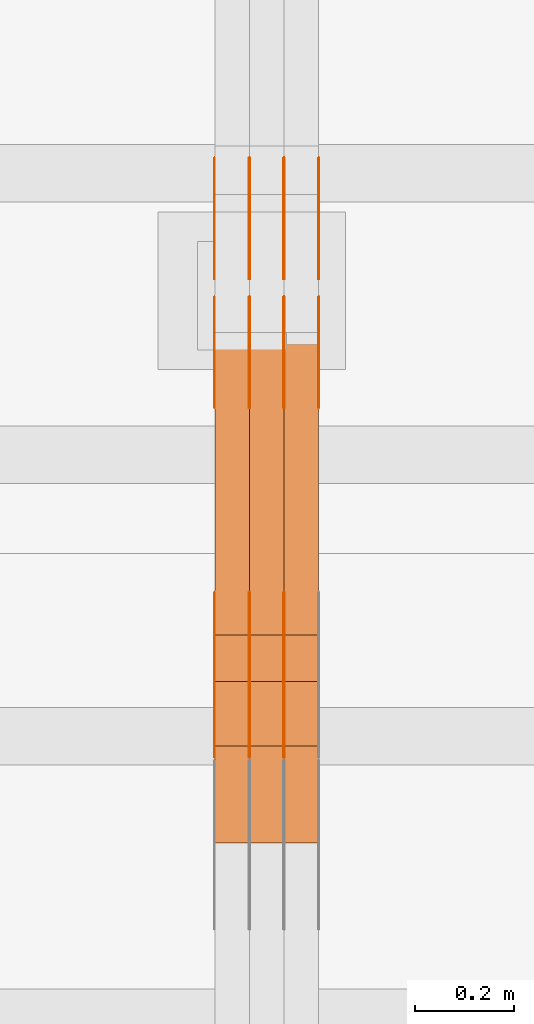
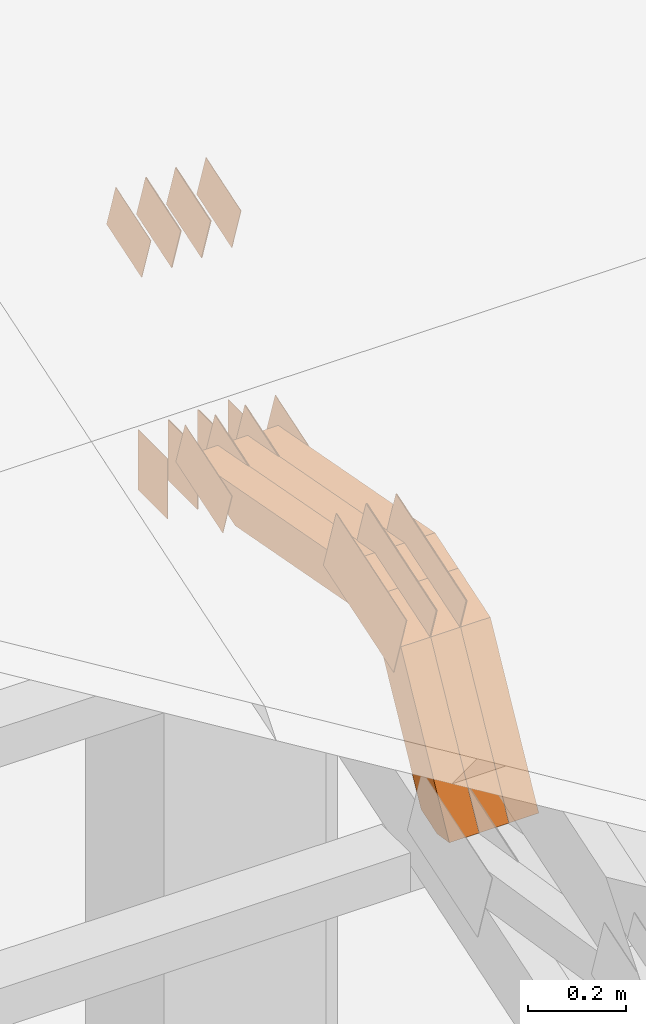
# One storey, part 153 of 385: 29 proxies.
"""IFC2X3 building model written with IfcOpenShell, lengths in millimetres."""

from ifc_helpers import new_model, entity, si_unit, converted_unit, derived_unit, direction, frame, frame_2d, origin, place, context, subcontext, project, spatial, polyline, rectangle, outline, extrude, source, transform, mapped, material, type_object, type_shapes, element, save


model = new_model("IFC2X3")

# Units and contexts
model_context = context("Model", 3, precision=0.01, world=origin(), true_north=direction((6.12303176911189e-17, 1.0)))
body_context = subcontext(model_context, "Body", "Model", "MODEL_VIEW")
ifc_project = project(units=[si_unit("LENGTHUNIT", "METRE", prefix="MILLI"), si_unit("AREAUNIT", "SQUARE_METRE"), si_unit("VOLUMEUNIT", "CUBIC_METRE"), converted_unit("PLANEANGLEUNIT", "DEGREE", entity("IfcRatioMeasure", 0.0174532925199433), si_unit("PLANEANGLEUNIT", "RADIAN"), dimensions=[0, 0, 0, 0, 0, 0, 0]), si_unit("MASSUNIT", "GRAM", prefix="KILO"), derived_unit("MASSDENSITYUNIT", [(si_unit("MASSUNIT", "GRAM", prefix="KILO"), 1), (si_unit("LENGTHUNIT", "METRE"), -3)]), si_unit("TIMEUNIT", "SECOND"), si_unit("FREQUENCYUNIT", "HERTZ"), si_unit("THERMODYNAMICTEMPERATUREUNIT", "DEGREE_CELSIUS"), derived_unit("THERMALTRANSMITTANCEUNIT", [(si_unit("MASSUNIT", "GRAM", prefix="KILO"), 1), (si_unit("THERMODYNAMICTEMPERATUREUNIT", "KELVIN"), -1), (si_unit("TIMEUNIT", "SECOND"), -3)]), derived_unit("VOLUMETRICFLOWRATEUNIT", [(si_unit("LENGTHUNIT", "METRE"), 3), (si_unit("TIMEUNIT", "SECOND"), -1)]), si_unit("ELECTRICCURRENTUNIT", "AMPERE"), si_unit("ELECTRICVOLTAGEUNIT", "VOLT"), si_unit("POWERUNIT", "WATT"), si_unit("FORCEUNIT", "NEWTON", prefix="KILO"), si_unit("ILLUMINANCEUNIT", "LUX"), si_unit("LUMINOUSFLUXUNIT", "LUMEN"), si_unit("LUMINOUSINTENSITYUNIT", "CANDELA"), derived_unit("USERDEFINED", [(si_unit("MASSUNIT", "GRAM", prefix="KILO"), -1), (si_unit("LENGTHUNIT", "METRE"), -2), (si_unit("TIMEUNIT", "SECOND"), 3), (si_unit("LUMINOUSFLUXUNIT", "LUMEN"), 1)]), derived_unit("LINEARVELOCITYUNIT", [(si_unit("LENGTHUNIT", "METRE"), 1), (si_unit("TIMEUNIT", "SECOND"), -1)]), si_unit("PRESSUREUNIT", "PASCAL"), derived_unit("USERDEFINED", [(si_unit("LENGTHUNIT", "METRE"), -2), (si_unit("MASSUNIT", "GRAM", prefix="KILO"), 1), (si_unit("TIMEUNIT", "SECOND"), -2)])], contexts=[model_context])

# Site, building, storey
site_placement = place(None, origin())
site = spatial("IfcSite", under=ifc_project, at=site_placement, CompositionType="ELEMENT")
building_placement = place(site_placement, origin())
building = spatial("IfcBuilding", under=site, at=building_placement, CompositionType="ELEMENT")
storey_placement = place(building_placement, origin())
storey = spatial("IfcBuildingStorey", under=building, at=storey_placement, Name="Default", CompositionType="ELEMENT", Elevation=0.0)

# Proxies
ifc_material_1 = material(Name="IfcSurfaceStyle #310384")
building_element_proxy_type_1 = type_object("IfcBuildingElementProxyType", PredefinedType="NOTDEFINED", material=ifc_material_1)
shared_shape_1 = source(origin(), body_context, "Body", "SweptSolid", [
    extrude(outline(polyline([(-99.9997874178038, -60.0000528641967), (99.9998102700997, -60.0000528641967), (99.9998251396068, 60.0000528641967), (-99.9998479919027, 60.0000528641967), (-99.9997874178038, -60.0000528641967)])), frame((99.9999918898597, 60.0000528641967, 0.0), z_axis=(0.0, 0.0, 1.0), x_axis=(-1.0, 0.0, 0.0)), (0.0, 0.0, 1.0), 1.3),
])
type_shapes(building_element_proxy_type_1, [shared_shape_1])
proxy_1_placement = place(building_placement, frame((24386.3, 11991.9568177725, 3072.52282247925), z_axis=(-1.0, 0.0, 0.0), x_axis=(0.0, 0.951056516295124, 0.309016994375039)))
element("IfcBuildingElementProxy", 1, at=proxy_1_placement, inside=storey, type_object=building_element_proxy_type_1, material=ifc_material_1, context=body_context, shape_type="MappedRepresentation", body=[
    mapped(shared_shape_1, transform((0.0, 0.0, 0.0), scale=1.0)),
])
ifc_material_2 = material(Name="IfcSurfaceStyle #310327")
building_element_proxy_type_2 = type_object("IfcBuildingElementProxyType", PredefinedType="NOTDEFINED", material=ifc_material_2)
shared_shape_2 = source(origin(), body_context, "Body", "SweptSolid", [
    extrude(outline(polyline([(-99.9997874178038, -60.0000528641967), (99.9998102700997, -60.0000528641967), (99.9998251396068, 60.0000528641967), (-99.9998479919027, 60.0000528641967), (-99.9997874178038, -60.0000528641967)])), frame((99.9999918898597, 60.0000528641967, 0.0), z_axis=(0.0, 0.0, 1.0), x_axis=(-1.0, 0.0, 0.0)), (0.0, 0.0, 1.0), 1.3),
])
type_shapes(building_element_proxy_type_2, [shared_shape_2])
proxy_2_placement = place(building_placement, frame((24315.0, 11991.9568177725, 3072.52282247925), z_axis=(-1.0, 0.0, 0.0), x_axis=(0.0, 0.951056516295124, 0.309016994375039)))
element("IfcBuildingElementProxy", 2, at=proxy_2_placement, inside=storey, type_object=building_element_proxy_type_2, material=ifc_material_2, context=body_context, shape_type="MappedRepresentation", body=[
    mapped(shared_shape_2, transform((0.0, 0.0, 0.0), scale=1.0)),
])
ifc_material_3 = material(Name="IfcSurfaceStyle #310270")
building_element_proxy_type_3 = type_object("IfcBuildingElementProxyType", PredefinedType="NOTDEFINED", material=ifc_material_3)
shared_shape_3 = source(origin(), body_context, "Body", "SweptSolid", [
    extrude(outline(polyline([(-99.9997874178038, -60.0000528641967), (99.9998102700997, -60.0000528641967), (99.9998251396068, 60.0000528641967), (-99.9998479919027, 60.0000528641967), (-99.9997874178038, -60.0000528641967)])), frame((99.9999918898597, 60.0000528641967, 0.0), z_axis=(0.0, 0.0, 1.0), x_axis=(-1.0, 0.0, 0.0)), (0.0, 0.0, 1.0), 1.3),
])
type_shapes(building_element_proxy_type_3, [shared_shape_3])
proxy_3_placement = place(building_placement, frame((24316.3, 11991.9568177725, 3072.52282247925), z_axis=(-1.0, 0.0, 0.0), x_axis=(0.0, 0.951056516295124, 0.309016994375039)))
element("IfcBuildingElementProxy", 3, at=proxy_3_placement, inside=storey, type_object=building_element_proxy_type_3, material=ifc_material_3, context=body_context, shape_type="MappedRepresentation", body=[
    mapped(shared_shape_3, transform((0.0, 0.0, 0.0), scale=1.0)),
])
ifc_material_4 = material(Name="IfcSurfaceStyle #310213")
building_element_proxy_type_4 = type_object("IfcBuildingElementProxyType", PredefinedType="NOTDEFINED", material=ifc_material_4)
shared_shape_4 = source(origin(), body_context, "Body", "SweptSolid", [
    extrude(outline(polyline([(-99.9997874178038, -60.0000528641967), (99.9998102700997, -60.0000528641967), (99.9998251396068, 60.0000528641967), (-99.9998479919027, 60.0000528641967), (-99.9997874178038, -60.0000528641967)])), frame((99.9999918898597, 60.0000528641967, 0.0), z_axis=(0.0, 0.0, 1.0), x_axis=(-1.0, 0.0, 0.0)), (0.0, 0.0, 1.0), 1.29999999999998),
])
type_shapes(building_element_proxy_type_4, [shared_shape_4])
proxy_4_placement = place(building_placement, frame((24245.0, 11991.9568177725, 3072.52282247925), z_axis=(-1.0, 0.0, 0.0), x_axis=(0.0, 0.951056516295124, 0.309016994375039)))
element("IfcBuildingElementProxy", 4, at=proxy_4_placement, inside=storey, type_object=building_element_proxy_type_4, material=ifc_material_4, context=body_context, shape_type="MappedRepresentation", body=[
    mapped(shared_shape_4, transform((0.0, 0.0, 0.0), scale=1.0)),
])
ifc_material_5 = material(Name="IfcSurfaceStyle #310156")
building_element_proxy_type_5 = type_object("IfcBuildingElementProxyType", PredefinedType="NOTDEFINED", material=ifc_material_5)
shared_shape_5 = source(origin(), body_context, "Body", "SweptSolid", [
    extrude(outline(polyline([(-99.9997874178038, -60.0000528641967), (99.9998102700997, -60.0000528641967), (99.9998251396068, 60.0000528641967), (-99.9998479919027, 60.0000528641967), (-99.9997874178038, -60.0000528641967)])), frame((99.9999918898597, 60.0000528641967, 0.0), z_axis=(0.0, 0.0, 1.0), x_axis=(-1.0, 0.0, 0.0)), (0.0, 0.0, 1.0), 1.29999999999998),
])
type_shapes(building_element_proxy_type_5, [shared_shape_5])
proxy_5_placement = place(building_placement, frame((24246.3, 11991.9568177725, 3072.52282247925), z_axis=(-1.0, 0.0, 0.0), x_axis=(0.0, 0.951056516295124, 0.309016994375039)))
element("IfcBuildingElementProxy", 5, at=proxy_5_placement, inside=storey, type_object=building_element_proxy_type_5, material=ifc_material_5, context=body_context, shape_type="MappedRepresentation", body=[
    mapped(shared_shape_5, transform((0.0, 0.0, 0.0), scale=1.0)),
])
ifc_material_6 = material(Name="IfcSurfaceStyle #310099")
building_element_proxy_type_6 = type_object("IfcBuildingElementProxyType", PredefinedType="NOTDEFINED", material=ifc_material_6)
shared_shape_6 = source(origin(), body_context, "Body", "SweptSolid", [
    extrude(outline(polyline([(-99.9997874178038, -60.0000528641967), (99.9998102700997, -60.0000528641967), (99.9998251396068, 60.0000528641967), (-99.9998479919027, 60.0000528641967), (-99.9997874178038, -60.0000528641967)])), frame((99.9999918898597, 60.0000528641967, 0.0), z_axis=(0.0, 0.0, 1.0), x_axis=(-1.0, 0.0, 0.0)), (0.0, 0.0, 1.0), 1.29999999999999),
])
type_shapes(building_element_proxy_type_6, [shared_shape_6])
proxy_6_placement = place(building_placement, frame((24175.0, 11991.9568177725, 3072.52282247925), z_axis=(-1.0, 0.0, 0.0), x_axis=(0.0, 0.951056516295124, 0.309016994375039)))
element("IfcBuildingElementProxy", 6, at=proxy_6_placement, inside=storey, type_object=building_element_proxy_type_6, material=ifc_material_6, context=body_context, shape_type="MappedRepresentation", body=[
    mapped(shared_shape_6, transform((0.0, 0.0, 0.0), scale=1.0)),
])
ifc_material_7 = material(Name="IfcSurfaceStyle #310042")
building_element_proxy_type_7 = type_object("IfcBuildingElementProxyType", PredefinedType="NOTDEFINED", material=ifc_material_7)
shared_shape_7 = source(origin(), body_context, "Body", "SweptSolid", [
    extrude(rectangle(XDim=150.0, YDim=119.999999999985, at=frame_2d((-7.105427357601e-15, 0.0), x_axis=(1.0, 0.0))), frame((75.0, 60.0, 0.0), z_axis=(0.0, 0.0, 1.0), x_axis=(-1.0, 0.0, 0.0)), (0.0, 0.0, 1.0), 1.3),
])
type_shapes(building_element_proxy_type_7, [shared_shape_7])
proxy_7_placement = place(building_placement, frame((24386.3, 12372.95703125, 3007.04687500001), z_axis=(-1.0, 0.0, 0.0), x_axis=(0.0, 0.0, -1.0)))
element("IfcBuildingElementProxy", 7, at=proxy_7_placement, inside=storey, type_object=building_element_proxy_type_7, material=ifc_material_7, context=body_context, shape_type="MappedRepresentation", body=[
    mapped(shared_shape_7, transform((0.0, 0.0, 0.0), scale=1.0)),
])
ifc_material_8 = material(Name="IfcSurfaceStyle #309985")
building_element_proxy_type_8 = type_object("IfcBuildingElementProxyType", PredefinedType="NOTDEFINED", material=ifc_material_8)
shared_shape_8 = source(origin(), body_context, "Body", "SweptSolid", [
    extrude(rectangle(XDim=150.0, YDim=119.999999999985, at=frame_2d((-7.105427357601e-15, 0.0), x_axis=(1.0, 0.0))), frame((75.0, 60.0, 0.0), z_axis=(0.0, 0.0, 1.0), x_axis=(-1.0, 0.0, 0.0)), (0.0, 0.0, 1.0), 1.3),
])
type_shapes(building_element_proxy_type_8, [shared_shape_8])
proxy_8_placement = place(building_placement, frame((24315.0, 12372.95703125, 3007.04687500001), z_axis=(-1.0, 0.0, 0.0), x_axis=(0.0, 0.0, -1.0)))
element("IfcBuildingElementProxy", 8, at=proxy_8_placement, inside=storey, type_object=building_element_proxy_type_8, material=ifc_material_8, context=body_context, shape_type="MappedRepresentation", body=[
    mapped(shared_shape_8, transform((0.0, 0.0, 0.0), scale=1.0)),
])
ifc_material_9 = material(Name="IfcSurfaceStyle #309928")
building_element_proxy_type_9 = type_object("IfcBuildingElementProxyType", PredefinedType="NOTDEFINED", material=ifc_material_9)
shared_shape_9 = source(origin(), body_context, "Body", "SweptSolid", [
    extrude(rectangle(XDim=150.0, YDim=119.999999999985, at=frame_2d((-7.105427357601e-15, 0.0), x_axis=(1.0, 0.0))), frame((75.0, 60.0, 0.0), z_axis=(0.0, 0.0, 1.0), x_axis=(-1.0, 0.0, 0.0)), (0.0, 0.0, 1.0), 1.3),
])
type_shapes(building_element_proxy_type_9, [shared_shape_9])
proxy_9_placement = place(building_placement, frame((24316.3, 12372.95703125, 3007.04687500001), z_axis=(-1.0, 0.0, 0.0), x_axis=(0.0, 0.0, -1.0)))
element("IfcBuildingElementProxy", 9, at=proxy_9_placement, inside=storey, type_object=building_element_proxy_type_9, material=ifc_material_9, context=body_context, shape_type="MappedRepresentation", body=[
    mapped(shared_shape_9, transform((0.0, 0.0, 0.0), scale=1.0)),
])
ifc_material_10 = material(Name="IfcSurfaceStyle #309871")
building_element_proxy_type_10 = type_object("IfcBuildingElementProxyType", PredefinedType="NOTDEFINED", material=ifc_material_10)
shared_shape_10 = source(origin(), body_context, "Body", "SweptSolid", [
    extrude(rectangle(XDim=150.0, YDim=119.999999999985, at=frame_2d((-7.105427357601e-15, 0.0), x_axis=(1.0, 0.0))), frame((75.0, 60.0, 0.0), z_axis=(0.0, 0.0, 1.0), x_axis=(-1.0, 0.0, 0.0)), (0.0, 0.0, 1.0), 1.29999999999999),
])
type_shapes(building_element_proxy_type_10, [shared_shape_10])
proxy_10_placement = place(building_placement, frame((24245.0, 12372.95703125, 3007.04687500001), z_axis=(-1.0, 0.0, 0.0), x_axis=(0.0, 0.0, -1.0)))
element("IfcBuildingElementProxy", 10, at=proxy_10_placement, inside=storey, type_object=building_element_proxy_type_10, material=ifc_material_10, context=body_context, shape_type="MappedRepresentation", body=[
    mapped(shared_shape_10, transform((0.0, 0.0, 0.0), scale=1.0)),
])
ifc_material_11 = material(Name="IfcSurfaceStyle #309814")
building_element_proxy_type_11 = type_object("IfcBuildingElementProxyType", PredefinedType="NOTDEFINED", material=ifc_material_11)
shared_shape_11 = source(origin(), body_context, "Body", "SweptSolid", [
    extrude(rectangle(XDim=150.0, YDim=119.999999999985, at=frame_2d((-7.105427357601e-15, 0.0), x_axis=(1.0, 0.0))), frame((75.0, 60.0, 0.0), z_axis=(0.0, 0.0, 1.0), x_axis=(-1.0, 0.0, 0.0)), (0.0, 0.0, 1.0), 1.29999999999999),
])
type_shapes(building_element_proxy_type_11, [shared_shape_11])
proxy_11_placement = place(building_placement, frame((24246.3, 12372.95703125, 3007.04687500001), z_axis=(-1.0, 0.0, 0.0), x_axis=(0.0, 0.0, -1.0)))
element("IfcBuildingElementProxy", 11, at=proxy_11_placement, inside=storey, type_object=building_element_proxy_type_11, material=ifc_material_11, context=body_context, shape_type="MappedRepresentation", body=[
    mapped(shared_shape_11, transform((0.0, 0.0, 0.0), scale=1.0)),
])
ifc_material_12 = material(Name="IfcSurfaceStyle #309757")
building_element_proxy_type_12 = type_object("IfcBuildingElementProxyType", PredefinedType="NOTDEFINED", material=ifc_material_12)
shared_shape_12 = source(origin(), body_context, "Body", "SweptSolid", [
    extrude(rectangle(XDim=150.0, YDim=119.999999999985, at=frame_2d((-7.105427357601e-15, 0.0), x_axis=(1.0, 0.0))), frame((75.0, 60.0, 0.0), z_axis=(0.0, 0.0, 1.0), x_axis=(-1.0, 0.0, 0.0)), (0.0, 0.0, 1.0), 1.29999999999999),
])
type_shapes(building_element_proxy_type_12, [shared_shape_12])
proxy_12_placement = place(building_placement, frame((24175.0, 12372.95703125, 3007.04687500001), z_axis=(-1.0, 0.0, 0.0), x_axis=(0.0, 0.0, -1.0)))
element("IfcBuildingElementProxy", 12, at=proxy_12_placement, inside=storey, type_object=building_element_proxy_type_12, material=ifc_material_12, context=body_context, shape_type="MappedRepresentation", body=[
    mapped(shared_shape_12, transform((0.0, 0.0, 0.0), scale=1.0)),
])
ifc_material_13 = material(Name="IfcSurfaceStyle #302860")
building_element_proxy_type_13 = type_object("IfcBuildingElementProxyType", PredefinedType="NOTDEFINED", material=ifc_material_13)
shared_shape_13 = source(origin(), body_context, "Body", "SweptSolid", [
    extrude(outline(polyline([(-74.9998754286244, -60.0000016373506), (74.9998605591063, -60.0000016373506), (74.9998754286244, 60.0000016373506), (-74.9998605591063, 60.0000016373506), (-74.9998754286244, -60.0000016373506)])), frame((74.9998754286244, 60.0000016373506, 0.0), z_axis=(0.0, 0.0, 1.0), x_axis=(-1.0, 0.0, 0.0)), (0.0, 0.0, 1.0), 1.3),
])
type_shapes(building_element_proxy_type_13, [shared_shape_13])
proxy_13_placement = place(building_placement, frame((24386.3, 12321.1620861463, 3506.17707344366), z_axis=(-1.0, 0.0, 0.0), x_axis=(0.0, 0.951056516295154, 0.309016994374948)))
element("IfcBuildingElementProxy", 13, at=proxy_13_placement, inside=storey, type_object=building_element_proxy_type_13, material=ifc_material_13, context=body_context, shape_type="MappedRepresentation", body=[
    mapped(shared_shape_13, transform((0.0, 0.0, 0.0), scale=1.0)),
])
ifc_material_14 = material(Name="IfcSurfaceStyle #302803")
building_element_proxy_type_14 = type_object("IfcBuildingElementProxyType", PredefinedType="NOTDEFINED", material=ifc_material_14)
shared_shape_14 = source(origin(), body_context, "Body", "SweptSolid", [
    extrude(outline(polyline([(-74.9998754286244, -60.0000016373506), (74.9998605591063, -60.0000016373506), (74.9998754286244, 60.0000016373506), (-74.9998605591063, 60.0000016373506), (-74.9998754286244, -60.0000016373506)])), frame((74.9998754286244, 60.0000016373506, 0.0), z_axis=(0.0, 0.0, 1.0), x_axis=(-1.0, 0.0, 0.0)), (0.0, 0.0, 1.0), 1.3),
])
type_shapes(building_element_proxy_type_14, [shared_shape_14])
proxy_14_placement = place(building_placement, frame((24315.0, 12321.1620861463, 3506.17707344366), z_axis=(-1.0, 0.0, 0.0), x_axis=(0.0, 0.951056516295154, 0.309016994374948)))
element("IfcBuildingElementProxy", 14, at=proxy_14_placement, inside=storey, type_object=building_element_proxy_type_14, material=ifc_material_14, context=body_context, shape_type="MappedRepresentation", body=[
    mapped(shared_shape_14, transform((0.0, 0.0, 0.0), scale=1.0)),
])
ifc_material_15 = material(Name="IfcSurfaceStyle #302746")
building_element_proxy_type_15 = type_object("IfcBuildingElementProxyType", PredefinedType="NOTDEFINED", material=ifc_material_15)
shared_shape_15 = source(origin(), body_context, "Body", "SweptSolid", [
    extrude(outline(polyline([(-74.9998754286244, -60.0000016373506), (74.9998605591063, -60.0000016373506), (74.9998754286244, 60.0000016373506), (-74.9998605591063, 60.0000016373506), (-74.9998754286244, -60.0000016373506)])), frame((74.9998754286244, 60.0000016373506, 0.0), z_axis=(0.0, 0.0, 1.0), x_axis=(-1.0, 0.0, 0.0)), (0.0, 0.0, 1.0), 1.3),
])
type_shapes(building_element_proxy_type_15, [shared_shape_15])
proxy_15_placement = place(building_placement, frame((24316.3, 12321.1620861463, 3506.17707344366), z_axis=(-1.0, 0.0, 0.0), x_axis=(0.0, 0.951056516295154, 0.309016994374948)))
element("IfcBuildingElementProxy", 15, at=proxy_15_placement, inside=storey, type_object=building_element_proxy_type_15, material=ifc_material_15, context=body_context, shape_type="MappedRepresentation", body=[
    mapped(shared_shape_15, transform((0.0, 0.0, 0.0), scale=1.0)),
])
ifc_material_16 = material(Name="IfcSurfaceStyle #302689")
building_element_proxy_type_16 = type_object("IfcBuildingElementProxyType", PredefinedType="NOTDEFINED", material=ifc_material_16)
shared_shape_16 = source(origin(), body_context, "Body", "SweptSolid", [
    extrude(outline(polyline([(-74.9998754286244, -60.0000016373506), (74.9998605591063, -60.0000016373506), (74.9998754286244, 60.0000016373506), (-74.9998605591063, 60.0000016373506), (-74.9998754286244, -60.0000016373506)])), frame((74.9998754286244, 60.0000016373506, 0.0), z_axis=(0.0, 0.0, 1.0), x_axis=(-1.0, 0.0, 0.0)), (0.0, 0.0, 1.0), 1.29999999999999),
])
type_shapes(building_element_proxy_type_16, [shared_shape_16])
proxy_16_placement = place(building_placement, frame((24245.0, 12321.1620861463, 3506.17707344366), z_axis=(-1.0, 0.0, 0.0), x_axis=(0.0, 0.951056516295154, 0.309016994374948)))
element("IfcBuildingElementProxy", 16, at=proxy_16_placement, inside=storey, type_object=building_element_proxy_type_16, material=ifc_material_16, context=body_context, shape_type="MappedRepresentation", body=[
    mapped(shared_shape_16, transform((0.0, 0.0, 0.0), scale=1.0)),
])
ifc_material_17 = material(Name="IfcSurfaceStyle #302632")
building_element_proxy_type_17 = type_object("IfcBuildingElementProxyType", PredefinedType="NOTDEFINED", material=ifc_material_17)
shared_shape_17 = source(origin(), body_context, "Body", "SweptSolid", [
    extrude(outline(polyline([(-74.9998754286244, -60.0000016373506), (74.9998605591063, -60.0000016373506), (74.9998754286244, 60.0000016373506), (-74.9998605591063, 60.0000016373506), (-74.9998754286244, -60.0000016373506)])), frame((74.9998754286244, 60.0000016373506, 0.0), z_axis=(0.0, 0.0, 1.0), x_axis=(-1.0, 0.0, 0.0)), (0.0, 0.0, 1.0), 1.29999999999999),
])
type_shapes(building_element_proxy_type_17, [shared_shape_17])
proxy_17_placement = place(building_placement, frame((24246.3, 12321.1620861463, 3506.17707344366), z_axis=(-1.0, 0.0, 0.0), x_axis=(0.0, 0.951056516295154, 0.309016994374948)))
element("IfcBuildingElementProxy", 17, at=proxy_17_placement, inside=storey, type_object=building_element_proxy_type_17, material=ifc_material_17, context=body_context, shape_type="MappedRepresentation", body=[
    mapped(shared_shape_17, transform((0.0, 0.0, 0.0), scale=1.0)),
])
ifc_material_18 = material(Name="IfcSurfaceStyle #302575")
building_element_proxy_type_18 = type_object("IfcBuildingElementProxyType", PredefinedType="NOTDEFINED", material=ifc_material_18)
shared_shape_18 = source(origin(), body_context, "Body", "SweptSolid", [
    extrude(outline(polyline([(-74.9998754286244, -60.0000016373506), (74.9998605591063, -60.0000016373506), (74.9998754286244, 60.0000016373506), (-74.9998605591063, 60.0000016373506), (-74.9998754286244, -60.0000016373506)])), frame((74.9998754286244, 60.0000016373506, 0.0), z_axis=(0.0, 0.0, 1.0), x_axis=(-1.0, 0.0, 0.0)), (0.0, 0.0, 1.0), 1.29999999999999),
])
type_shapes(building_element_proxy_type_18, [shared_shape_18])
proxy_18_placement = place(building_placement, frame((24175.0, 12321.1620861463, 3506.17707344366), z_axis=(-1.0, 0.0, 0.0), x_axis=(0.0, 0.951056516295154, 0.309016994374948)))
element("IfcBuildingElementProxy", 18, at=proxy_18_placement, inside=storey, type_object=building_element_proxy_type_18, material=ifc_material_18, context=body_context, shape_type="MappedRepresentation", body=[
    mapped(shared_shape_18, transform((0.0, 0.0, 0.0), scale=1.0)),
])
ifc_material_19 = material(Name="IfcSurfaceStyle #302119")
building_element_proxy_type_19 = type_object("IfcBuildingElementProxyType", PredefinedType="NOTDEFINED", material=ifc_material_19)
shared_shape_19 = source(origin(), body_context, "Body", "SweptSolid", [
    extrude(outline(polyline([(-150.000273478628, -84.0002987844282), (149.999198496832, -84.0002987844282), (150.000273478627, 84.0002987844282), (-149.999198496831, 84.0002987844282), (-150.000273478628, -84.0002987844282)])), frame((150.000273478627, 84.0002987844282, 0.0), z_axis=(0.0, 0.0, 1.0), x_axis=(-1.0, 0.0, 0.0)), (0.0, 0.0, 1.0), 1.29999999999999),
])
type_shapes(building_element_proxy_type_19, [shared_shape_19])
proxy_19_placement = place(building_placement, frame((24315.0, 11283.0116722926, 3194.09682266857), z_axis=(-1.0, 0.0, 0.0), x_axis=(0.0, 0.951056516295154, 0.309016994374948)))
element("IfcBuildingElementProxy", 19, at=proxy_19_placement, inside=storey, type_object=building_element_proxy_type_19, material=ifc_material_19, context=body_context, shape_type="MappedRepresentation", body=[
    mapped(shared_shape_19, transform((0.0, 0.0, 0.0), scale=1.0)),
])
ifc_material_20 = material(Name="IfcSurfaceStyle #302062")
building_element_proxy_type_20 = type_object("IfcBuildingElementProxyType", PredefinedType="NOTDEFINED", material=ifc_material_20)
shared_shape_20 = source(origin(), body_context, "Body", "SweptSolid", [
    extrude(outline(polyline([(-150.000273478628, -84.0002987844282), (149.999198496832, -84.0002987844282), (150.000273478627, 84.0002987844282), (-149.999198496831, 84.0002987844282), (-150.000273478628, -84.0002987844282)])), frame((150.000273478627, 84.0002987844282, 0.0), z_axis=(0.0, 0.0, 1.0), x_axis=(-1.0, 0.0, 0.0)), (0.0, 0.0, 1.0), 1.29999999999999),
])
type_shapes(building_element_proxy_type_20, [shared_shape_20])
proxy_20_placement = place(building_placement, frame((24316.3, 11283.0116722926, 3194.09682266857), z_axis=(-1.0, 0.0, 0.0), x_axis=(0.0, 0.951056516295154, 0.309016994374948)))
element("IfcBuildingElementProxy", 20, at=proxy_20_placement, inside=storey, type_object=building_element_proxy_type_20, material=ifc_material_20, context=body_context, shape_type="MappedRepresentation", body=[
    mapped(shared_shape_20, transform((0.0, 0.0, 0.0), scale=1.0)),
])
ifc_material_21 = material(Name="IfcSurfaceStyle #302005")
building_element_proxy_type_21 = type_object("IfcBuildingElementProxyType", PredefinedType="NOTDEFINED", material=ifc_material_21)
shared_shape_21 = source(origin(), body_context, "Body", "SweptSolid", [
    extrude(outline(polyline([(-150.000273478628, -84.0002987844282), (149.999198496832, -84.0002987844282), (150.000273478627, 84.0002987844282), (-149.999198496831, 84.0002987844282), (-150.000273478628, -84.0002987844282)])), frame((150.000273478627, 84.0002987844282, 0.0), z_axis=(0.0, 0.0, 1.0), x_axis=(-1.0, 0.0, 0.0)), (0.0, 0.0, 1.0), 1.29999999999998),
])
type_shapes(building_element_proxy_type_21, [shared_shape_21])
proxy_21_placement = place(building_placement, frame((24245.0, 11283.0116722926, 3194.09682266857), z_axis=(-1.0, 0.0, 0.0), x_axis=(0.0, 0.951056516295154, 0.309016994374948)))
element("IfcBuildingElementProxy", 21, at=proxy_21_placement, inside=storey, type_object=building_element_proxy_type_21, material=ifc_material_21, context=body_context, shape_type="MappedRepresentation", body=[
    mapped(shared_shape_21, transform((0.0, 0.0, 0.0), scale=1.0)),
])
ifc_material_22 = material(Name="IfcSurfaceStyle #301948")
building_element_proxy_type_22 = type_object("IfcBuildingElementProxyType", PredefinedType="NOTDEFINED", material=ifc_material_22)
shared_shape_22 = source(origin(), body_context, "Body", "SweptSolid", [
    extrude(outline(polyline([(-150.000273478628, -84.0002987844282), (149.999198496832, -84.0002987844282), (150.000273478627, 84.0002987844282), (-149.999198496831, 84.0002987844282), (-150.000273478628, -84.0002987844282)])), frame((150.000273478627, 84.0002987844282, 0.0), z_axis=(0.0, 0.0, 1.0), x_axis=(-1.0, 0.0, 0.0)), (0.0, 0.0, 1.0), 1.29999999999998),
])
type_shapes(building_element_proxy_type_22, [shared_shape_22])
proxy_22_placement = place(building_placement, frame((24246.3, 11283.0116722926, 3194.09682266857), z_axis=(-1.0, 0.0, 0.0), x_axis=(0.0, 0.951056516295154, 0.309016994374948)))
element("IfcBuildingElementProxy", 22, at=proxy_22_placement, inside=storey, type_object=building_element_proxy_type_22, material=ifc_material_22, context=body_context, shape_type="MappedRepresentation", body=[
    mapped(shared_shape_22, transform((0.0, 0.0, 0.0), scale=1.0)),
])
ifc_material_23 = material(Name="IfcSurfaceStyle #301891")
building_element_proxy_type_23 = type_object("IfcBuildingElementProxyType", PredefinedType="NOTDEFINED", material=ifc_material_23)
shared_shape_23 = source(origin(), body_context, "Body", "SweptSolid", [
    extrude(outline(polyline([(-150.000273478628, -84.0002987844282), (149.999198496832, -84.0002987844282), (150.000273478627, 84.0002987844282), (-149.999198496831, 84.0002987844282), (-150.000273478628, -84.0002987844282)])), frame((150.000273478627, 84.0002987844282, 0.0), z_axis=(0.0, 0.0, 1.0), x_axis=(-1.0, 0.0, 0.0)), (0.0, 0.0, 1.0), 1.29999999999998),
])
type_shapes(building_element_proxy_type_23, [shared_shape_23])
proxy_23_placement = place(building_placement, frame((24175.0, 11283.0116722926, 3194.09682266857), z_axis=(-1.0, 0.0, 0.0), x_axis=(0.0, 0.951056516295154, 0.309016994374948)))
element("IfcBuildingElementProxy", 23, at=proxy_23_placement, inside=storey, type_object=building_element_proxy_type_23, material=ifc_material_23, context=body_context, shape_type="MappedRepresentation", body=[
    mapped(shared_shape_23, transform((0.0, 0.0, 0.0), scale=1.0)),
])
ifc_material_24 = material(Name="IfcSurfaceStyle #291880")
building_element_proxy_type_24 = type_object("IfcBuildingElementProxyType", Name="T1-W9 291878", PredefinedType="NOTDEFINED", material=ifc_material_24)
shared_shape_24 = source(origin(), body_context, "Body", "SweptSolid", [
    extrude(outline(polyline([(-287.457507623288, -47.5000268597988), (288.590479960635, -47.5000268597988), (273.55062971372, -2.33146189358546e-05), (186.625054999886, 47.5000385171083), (-461.308657050953, 47.5000385171083), (-287.457507623288, -47.5000268597988)])), frame((288.590945855618, 47.5000968036551, 0.0), z_axis=(0.0, 0.0, 1.0), x_axis=(-1.0, 0.0, 0.0)), (0.0, 0.0, 1.0), 70.0),
])
type_shapes(building_element_proxy_type_24, [shared_shape_24])
proxy_24_placement = place(building_placement, frame((24385.0, 11432.1200855376, 3205.63308612017), z_axis=(-1.0, 0.0, 0.0), x_axis=(0.0, 0.982760503514031, -0.184883186722992)))
element("IfcBuildingElementProxy", 24, at=proxy_24_placement, inside=storey, type_object=building_element_proxy_type_24, material=ifc_material_24, Name="T1-W9", context=body_context, shape_type="MappedRepresentation", body=[
    mapped(shared_shape_24, transform((0.0, 0.0, 0.0), scale=1.0)),
])
ifc_material_25 = material(Name="IfcSurfaceStyle #291814")
building_element_proxy_type_25 = type_object("IfcBuildingElementProxyType", Name="T1-W9 291812", PredefinedType="NOTDEFINED", material=ifc_material_25)
shared_shape_25 = source(origin(), body_context, "Body", "SweptSolid", [
    extrude(outline(polyline([(-287.457507623288, -47.5000268597988), (288.590479960635, -47.5000268597988), (273.55062971372, -2.33146189358546e-05), (186.625054999886, 47.5000385171083), (-461.308657050953, 47.5000385171083), (-287.457507623288, -47.5000268597988)])), frame((288.590945855618, 47.5000968036551, 0.0), z_axis=(0.0, 0.0, 1.0), x_axis=(-1.0, 0.0, 0.0)), (0.0, 0.0, 1.0), 70.0),
])
type_shapes(building_element_proxy_type_25, [shared_shape_25])
proxy_25_placement = place(building_placement, frame((24315.0, 11432.1200855376, 3205.63308612017), z_axis=(-1.0, 0.0, 0.0), x_axis=(0.0, 0.982760503514031, -0.184883186722992)))
element("IfcBuildingElementProxy", 25, at=proxy_25_placement, inside=storey, type_object=building_element_proxy_type_25, material=ifc_material_25, Name="T1-W9", context=body_context, shape_type="MappedRepresentation", body=[
    mapped(shared_shape_25, transform((0.0, 0.0, 0.0), scale=1.0)),
])
ifc_material_26 = material(Name="IfcSurfaceStyle #291748")
building_element_proxy_type_26 = type_object("IfcBuildingElementProxyType", Name="T1-W9 291746", PredefinedType="NOTDEFINED", material=ifc_material_26)
shared_shape_26 = source(origin(), body_context, "Body", "SweptSolid", [
    extrude(outline(polyline([(-287.457507623288, -47.5000268597988), (288.590479960635, -47.5000268597988), (273.55062971372, -2.33146189358546e-05), (186.625054999886, 47.5000385171083), (-461.308657050953, 47.5000385171083), (-287.457507623288, -47.5000268597988)])), frame((288.590945855618, 47.5000968036551, 0.0), z_axis=(0.0, 0.0, 1.0), x_axis=(-1.0, 0.0, 0.0)), (0.0, 0.0, 1.0), 70.0),
])
type_shapes(building_element_proxy_type_26, [shared_shape_26])
proxy_26_placement = place(building_placement, frame((24245.0, 11432.1200855376, 3205.63308612017), z_axis=(-1.0, 0.0, 0.0), x_axis=(0.0, 0.982760503514031, -0.184883186722992)))
element("IfcBuildingElementProxy", 26, at=proxy_26_placement, inside=storey, type_object=building_element_proxy_type_26, material=ifc_material_26, Name="T1-W9", context=body_context, shape_type="MappedRepresentation", body=[
    mapped(shared_shape_26, transform((0.0, 0.0, 0.0), scale=1.0)),
])
ifc_material_27 = material(Name="IfcSurfaceStyle #291484")
building_element_proxy_type_27 = type_object("IfcBuildingElementProxyType", Name="T1-W32 291482", PredefinedType="NOTDEFINED", material=ifc_material_27)
shared_shape_27 = source(origin(), body_context, "Body", "SweptSolid", [
    extrude(outline(polyline([(-312.414547135921, -47.5000544873059), (136.677011757652, -47.5000544873059), (186.250996577889, 0.000369497452627243), (202.753116295831, 47.4998697385796), (-213.26657749545, 47.4998697385796), (-312.414547135921, -47.5000544873059)])), frame((202.753376481939, 47.5001296985553, 0.0), z_axis=(0.0, 0.0, 1.0), x_axis=(-1.0, 0.0, 0.0)), (0.0, 0.0, 1.0), 70.0),
])
type_shapes(building_element_proxy_type_27, [shared_shape_27])
proxy_27_placement = place(building_placement, frame((24385.0, 11110.7808979007, 2747.18129017315), z_axis=(-1.0, 0.0, 0.0), x_axis=(0.0, 0.472919689385906, 0.881105537033526)))
element("IfcBuildingElementProxy", 27, at=proxy_27_placement, inside=storey, type_object=building_element_proxy_type_27, material=ifc_material_27, Name="T1-W32", context=body_context, shape_type="MappedRepresentation", body=[
    mapped(shared_shape_27, transform((0.0, 0.0, 0.0), scale=1.0)),
])
ifc_material_28 = material(Name="IfcSurfaceStyle #291418")
building_element_proxy_type_28 = type_object("IfcBuildingElementProxyType", Name="T1-W32 291416", PredefinedType="NOTDEFINED", material=ifc_material_28)
shared_shape_28 = source(origin(), body_context, "Body", "SweptSolid", [
    extrude(outline(polyline([(-312.414547135921, -47.5000544873059), (136.677011757652, -47.5000544873059), (186.250996577889, 0.000369497452627243), (202.753116295831, 47.4998697385796), (-213.26657749545, 47.4998697385796), (-312.414547135921, -47.5000544873059)])), frame((202.753376481939, 47.5001296985553, 0.0), z_axis=(0.0, 0.0, 1.0), x_axis=(-1.0, 0.0, 0.0)), (0.0, 0.0, 1.0), 70.0),
])
type_shapes(building_element_proxy_type_28, [shared_shape_28])
proxy_28_placement = place(building_placement, frame((24315.0, 11110.7808979007, 2747.18129017315), z_axis=(-1.0, 0.0, 0.0), x_axis=(0.0, 0.472919689385906, 0.881105537033526)))
element("IfcBuildingElementProxy", 28, at=proxy_28_placement, inside=storey, type_object=building_element_proxy_type_28, material=ifc_material_28, Name="T1-W32", context=body_context, shape_type="MappedRepresentation", body=[
    mapped(shared_shape_28, transform((0.0, 0.0, 0.0), scale=1.0)),
])
ifc_material_29 = material(Name="IfcSurfaceStyle #291352")
building_element_proxy_type_29 = type_object("IfcBuildingElementProxyType", Name="T1-W32 291350", PredefinedType="NOTDEFINED", material=ifc_material_29)
shared_shape_29 = source(origin(), body_context, "Body", "SweptSolid", [
    extrude(outline(polyline([(-312.414547135921, -47.5000544873059), (136.677011757652, -47.5000544873059), (186.250996577889, 0.000369497452627243), (202.753116295831, 47.4998697385796), (-213.26657749545, 47.4998697385796), (-312.414547135921, -47.5000544873059)])), frame((202.753376481939, 47.5001296985553, 0.0), z_axis=(0.0, 0.0, 1.0), x_axis=(-1.0, 0.0, 0.0)), (0.0, 0.0, 1.0), 70.0),
])
type_shapes(building_element_proxy_type_29, [shared_shape_29])
proxy_29_placement = place(building_placement, frame((24245.0, 11110.7808979007, 2747.18129017315), z_axis=(-1.0, 0.0, 0.0), x_axis=(0.0, 0.472919689385906, 0.881105537033526)))
element("IfcBuildingElementProxy", 29, at=proxy_29_placement, inside=storey, type_object=building_element_proxy_type_29, material=ifc_material_29, Name="T1-W32", context=body_context, shape_type="MappedRepresentation", body=[
    mapped(shared_shape_29, transform((0.0, 0.0, 0.0), scale=1.0)),
])

save(model, "model.ifc")
